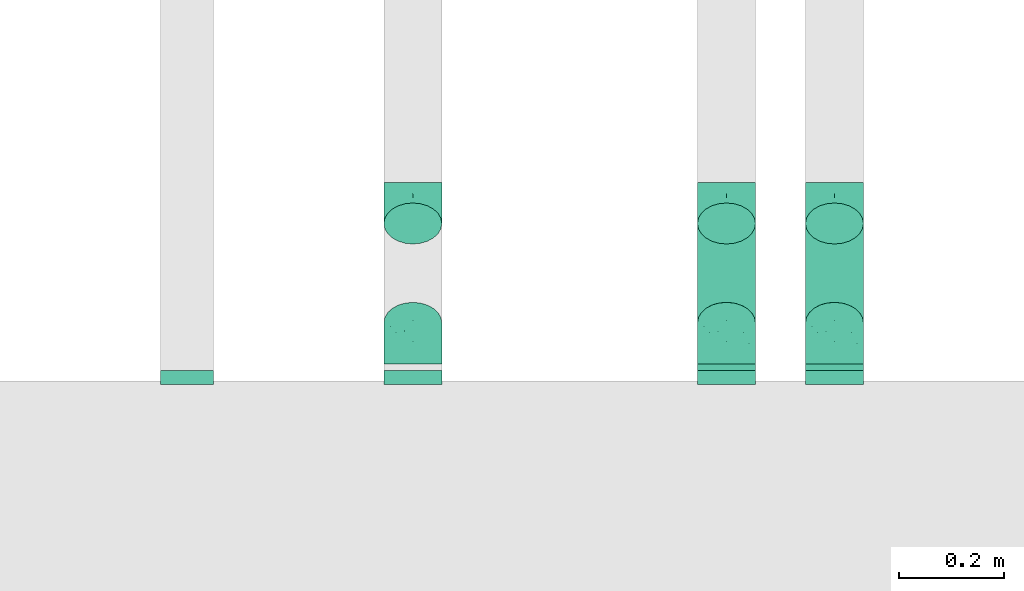
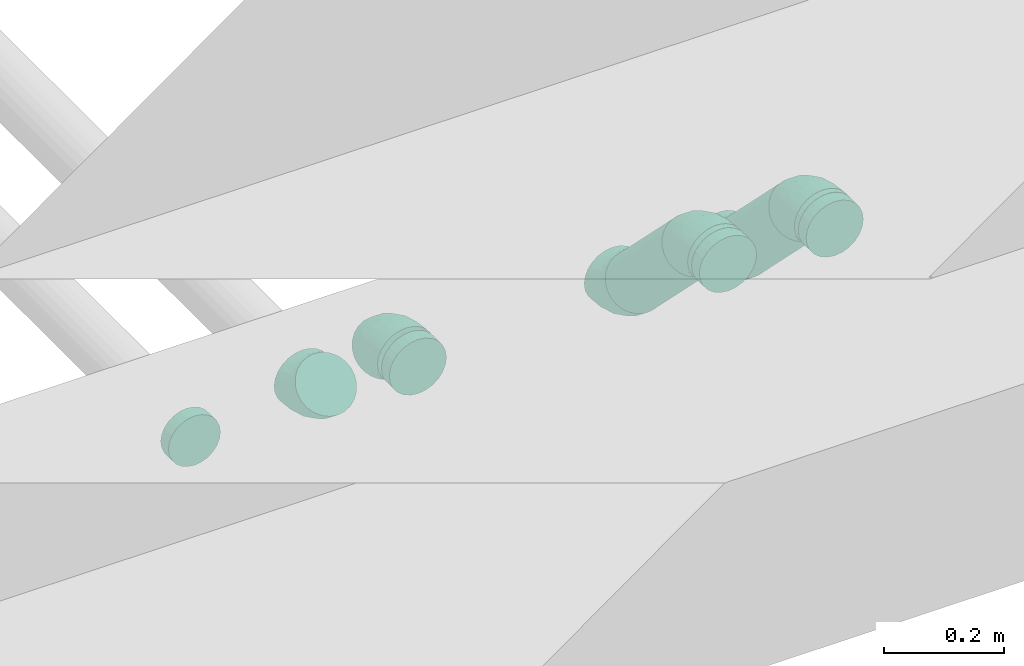
# One storey, part 33 of 91: 10 flow fittings, 4 flow segments.
"""IFC2X3 building model written with IfcOpenShell, lengths in millimetres."""

from ifc_helpers import new_model, entity, si_unit, converted_unit, derived_unit, direction, frame, origin_with_axes, origin_2d_with_axis, place, context, subcontext, project, spatial, hollow_circle, extrude, open_shell, surface_model, source, transform, mapped, material, layer, layer_set, layer_usage, type_object, element, save


model = new_model("IFC2X3")

# Units and contexts
model_context = context("Model", 3, precision=1e-05, world=origin_with_axes(), true_north=direction((0.0, 1.0)))
body_context = subcontext(model_context, "Body", "Model", "MODEL_VIEW")
ifc_project = project(units=[si_unit("AREAUNIT", "SQUARE_METRE"), si_unit("VOLUMEUNIT", "CUBIC_METRE", prefix="DECI"), si_unit("TIMEUNIT", "SECOND"), si_unit("THERMODYNAMICTEMPERATUREUNIT", "DEGREE_CELSIUS"), si_unit("PRESSUREUNIT", "PASCAL"), si_unit("MASSUNIT", "GRAM", prefix="KILO"), si_unit("LENGTHUNIT", "METRE", prefix="MILLI"), si_unit("POWERUNIT", "WATT"), si_unit("ELECTRICCURRENTUNIT", "AMPERE"), si_unit("ELECTRICVOLTAGEUNIT", "VOLT"), derived_unit("VOLUMETRICFLOWRATEUNIT", [(si_unit("VOLUMEUNIT", "CUBIC_METRE", prefix="DECI"), 1), (si_unit("TIMEUNIT", "SECOND"), -1)]), derived_unit("LINEARVELOCITYUNIT", [(si_unit("LENGTHUNIT", "METRE"), 1), (si_unit("TIMEUNIT", "SECOND"), -1)]), derived_unit("MASSDENSITYUNIT", [(si_unit("MASSUNIT", "GRAM", prefix="KILO"), 1), (si_unit("VOLUMEUNIT", "CUBIC_METRE"), -1)]), converted_unit("PLANEANGLEUNIT", "DEGREE", entity("IfcRatioMeasure", 0.01745), si_unit("PLANEANGLEUNIT", "RADIAN"), dimensions=[0, 0, 0, 0, 0, 0, 0])], contexts=[model_context])

# Site, building, storey
site_placement = place(None, origin_with_axes())
site = spatial("IfcSite", under=ifc_project, at=site_placement, CompositionType="ELEMENT")
building_placement = place(site_placement, origin_with_axes())
building = spatial("IfcBuilding", under=site, at=building_placement, Name="mc-building", CompositionType="ELEMENT")
storey_placement = place(building_placement, frame((0.0, 0.0, 8700.0), z_axis=(0.0, 0.0, 1.0), x_axis=(1.0, 0.0, 0.0)))
storey = spatial("IfcBuildingStorey", under=building, at=storey_placement, CompositionType="ELEMENT", Elevation=8700.0)

# Flow segments
ifc_material = material(Name="FZ1")
ifc_layer = layer(ifc_material, 0.0)
ifc_layer_set = layer_set([ifc_layer], Name="FZ1")
ifc_layer_usage = layer_usage(ifc_layer_set, "AXIS1", "POSITIVE", 0.0)
duct_segment_type = type_object("IfcDuctSegmentType", PredefinedType="RIGIDSEGMENT")
shared_shape_1 = source(origin_with_axes(), body_context, "Body", "SweptSolid", [
    extrude(hollow_circle(Radius=55.0, WallThickness=2.0, at=origin_2d_with_axis()), frame((0.0, 0.0, 0.0), z_axis=(1.0, 0.0, 0.0), x_axis=(0.0, 1.0, 0.0)), (0.0, 0.0, 1.0), 266.7),
])
for number, where, z_axis, x_axis in (
    (1, (15757.14677, 8401.1274, 635.78175), (0.0, 0.707107, 0.707107), (0.0, 0.707107, -0.707107)),
    (2, (15552.24709, 8401.1274, 635.78175), (0.0, 0.707107, 0.707107), (0.0, 0.707107, -0.707107)),
):
    element("IfcFlowSegment", number, at=place(storey_placement, frame(where, z_axis=z_axis, x_axis=x_axis)), inside=storey, type_object=duct_segment_type, material=ifc_layer_usage, context=body_context, shape_type="MappedRepresentation", body=[
        mapped(shared_shape_1, transform((0.0, 0.0, 0.0), scale=1.0)),
    ])

# Flow fittings
duct_fitting_type_1 = type_object("IfcDuctFittingType", Name="BU", PredefinedType="BEND")
shared_shape_2 = source(origin_with_axes(), body_context, "Body", "SurfaceModel", [
    surface_model("IfcShellBasedSurfaceModel", [(-45.56349, 0.0, -55.0), (-45.56349, -14.23505, -53.12592), (-45.56349, 14.23505, -53.12592), (-45.56349, 53.12592, 14.23505), (-45.56349, 27.5, -47.63139), (-45.56349, 38.89087, -38.89087), (-45.56349, 47.63139, -27.5), (-45.56349, -55.0, 0.0), (-45.56349, -53.12592, 14.23505), (-45.56349, -38.89087, -38.89087), (-45.56349, -27.5, -47.63139), (-45.56349, -53.12592, -14.23505), (-45.56349, -47.63139, -27.5), (-45.56349, 53.12592, -14.23505), (-45.56349, 47.63139, 27.5), (-45.56349, 38.89087, 38.89087), (-45.56349, -14.23505, 53.12592), (-45.56349, 27.5, 47.63139), (-45.56349, 14.23505, 53.12592), (-45.56349, -47.63139, 27.5), (-45.56349, -38.89087, 38.89087), (-45.56349, -27.5, 47.63139), (-45.56349, 0.0, 55.0), (-45.56349, 55.0, 0.0), (22.15256, 42.28395, -53.12592), (-6.67262, 71.10913, 0.0), (32.21826, 32.21826, -55.0), (12.77282, 51.66369, -47.63139), (-1.46223, 65.89874, -27.5), (4.71825, 59.71825, -38.89087), (59.71825, 4.71825, -38.89087), (69.78395, -5.34744, 14.23505), (51.66369, 12.77282, -47.63139), (42.28395, 22.15256, -53.12592), (65.89874, -1.46223, -27.5), (69.78395, -5.34744, -14.23505), (71.10913, -6.67262, 0.0), (-5.34744, 69.78395, -14.23505), (-5.34744, 69.78395, 14.23505), (-1.46223, 65.89874, 27.5), (4.71825, 59.71825, 38.89087), (32.21826, 32.21826, 55.0), (12.77282, 51.66369, 47.63139), (22.15256, 42.28395, 53.12592), (59.71825, 4.71825, 38.89087), (65.89874, -1.46223, 27.5), (42.28395, 22.15256, 53.12592), (51.66369, 12.77282, 47.63139), (-20.16649, 48.68621, 33.48188), (-26.97111, 35.77503, 43.63444), (-7.30443, 43.73336, 43.63444), (-17.0934, 3.74816, 55.0), (-18.00408, 15.44793, 53.78143), (-30.11707, 22.39897, 50.81337), (-7.49776, 55.63651, 33.48188), (-15.97018, 58.74288, 21.04759), (-31.18231, 52.58712, 21.04759), (-18.35174, 61.03934, 10.51509), (-28.67677, 56.60048, 10.47121), (-34.03924, 44.64267, 33.48188), (-11.52288, 27.81868, 50.81338), (1.19951, 23.16465, 53.81115), (-33.77926, 57.34403, 0.0), (5.4586, 37.12132, 50.81809), (-24.5159, 59.18663, 0.0), (-16.66281, 64.4339, 0.0), (9.43651, 14.73721, 55.0), (-6.22531, 44.36822, -43.63444), (5.4586, 37.12132, -50.81809), (-34.03924, 44.64267, -33.48188), (9.43651, 14.73721, -55.0), (-17.0934, 3.74816, -55.0), (1.19951, 23.16465, -53.81115), (-11.52288, 27.81868, -50.81338), (-30.11707, 22.39897, -50.81337), (-25.75914, 36.08917, -43.63444), (-30.24487, 52.83011, -21.04759), (-20.16649, 48.68621, -33.48188), (-7.49776, 55.63651, -33.48188), (-18.00408, 15.44793, -53.78143), (-28.68366, 56.62226, -10.35271), (-14.15883, 63.53074, -10.87592), (-15.13548, 59.23394, -21.04759), (3.19797, -7.72059, -52.16847), (3.1272, -18.04126, -47.9241), (13.63233, -32.91136, -32.06475), (45.23618, -22.99734, -20.4997), (16.67434, -40.25541, -15.9539), (-17.3935, -51.68264, -9.80849), (-2.85835, -49.37776, 0.0), (48.84421, -24.24609, -9.80849), (-16.38424, -42.76862, -30.85433), (-6.97383, -29.41689, -42.70541), (41.82739, -18.65658, -30.85433), (-15.72523, -48.24839, -20.4997), (29.28945, -13.63928, -42.80781), (26.81493, -3.56603, -49.15704), (36.93651, -32.89419, 0.0), (-15.72523, -48.24839, 20.4997), (-17.3935, -51.68264, 9.80849), (-16.38424, -42.76862, 30.85433), (16.67434, -40.25541, 15.9539), (3.19797, -7.72059, 52.16847), (10.54583, -14.96836, 47.9241), (13.63233, -32.91136, 32.06475), (45.23618, -22.99734, 20.4997), (41.82739, -18.65658, 30.85433), (-11.06635, -30.3552, 42.80781), (25.73213, -15.86964, 42.70541), (-16.43945, -21.48258, 49.15704), (48.84421, -24.24609, 9.80849)], [open_shell([[[0, 1, 2]], [[2, 3, 4]], [[5, 3, 6]], [[4, 3, 5]], [[2, 7, 8]], [[9, 7, 10]], [[1, 10, 7]], [[11, 7, 12]], [[9, 12, 7]], [[7, 2, 1]], [[13, 6, 3]], [[14, 3, 2]], [[15, 14, 2]], [[16, 17, 2]], [[2, 17, 15]], [[16, 18, 17]], [[19, 20, 2]], [[19, 2, 8]], [[20, 21, 2]], [[2, 21, 16]], [[16, 22, 18]], [[23, 13, 3]], [[24, 25, 26]], [[27, 25, 24]], [[28, 25, 29]], [[29, 25, 27]], [[30, 26, 31]], [[26, 30, 32]], [[32, 33, 26]], [[34, 31, 35]], [[31, 34, 30]], [[35, 31, 36]], [[37, 25, 28]], [[26, 38, 39]], [[26, 39, 40]], [[41, 40, 42]], [[26, 40, 41]], [[42, 43, 41]], [[26, 44, 45]], [[31, 26, 45]], [[46, 47, 26]], [[47, 44, 26]], [[46, 26, 41]], [[26, 25, 38]], [[48, 49, 50]], [[22, 51, 52]], [[17, 49, 15]], [[53, 17, 18]], [[49, 17, 53]], [[54, 50, 40]], [[48, 55, 56]], [[55, 57, 58]], [[59, 14, 15]], [[60, 53, 52]], [[50, 49, 60]], [[58, 3, 56]], [[52, 51, 61]], [[62, 23, 3]], [[63, 50, 60]], [[50, 42, 40]], [[3, 58, 62]], [[43, 61, 41]], [[62, 58, 64]], [[48, 59, 49]], [[14, 56, 3]], [[40, 39, 54]], [[57, 64, 58]], [[39, 38, 55]], [[63, 60, 61]], [[54, 55, 48]], [[65, 57, 38]], [[56, 14, 59]], [[38, 25, 65]], [[60, 52, 61]], [[49, 59, 15]], [[55, 58, 56]], [[56, 59, 48]], [[55, 54, 39]], [[50, 54, 48]], [[18, 22, 52]], [[49, 53, 60]], [[18, 52, 53]], [[61, 51, 66]], [[41, 61, 66]], [[63, 61, 43]], [[43, 42, 63]], [[50, 63, 42]], [[38, 57, 55]], [[64, 57, 65]], [[67, 27, 68]], [[69, 5, 6]], [[70, 71, 72]], [[73, 74, 75]], [[76, 77, 69]], [[29, 78, 28]], [[2, 79, 0]], [[13, 23, 62]], [[2, 74, 79]], [[5, 75, 4]], [[77, 78, 67]], [[13, 62, 80]], [[64, 80, 62]], [[81, 80, 64]], [[67, 73, 75]], [[82, 77, 76]], [[81, 64, 65]], [[76, 69, 6]], [[82, 76, 80]], [[24, 72, 68]], [[74, 2, 4]], [[27, 67, 29]], [[26, 70, 72]], [[69, 75, 5]], [[82, 28, 78]], [[72, 71, 79]], [[6, 13, 76]], [[77, 67, 75]], [[13, 80, 76]], [[82, 37, 28]], [[81, 25, 37]], [[82, 81, 37]], [[75, 69, 77]], [[67, 78, 29]], [[82, 78, 77]], [[75, 74, 4]], [[79, 74, 73]], [[79, 73, 72]], [[79, 71, 0]], [[68, 72, 73]], [[26, 72, 24]], [[67, 68, 73]], [[27, 24, 68]], [[80, 81, 82]], [[25, 81, 65]], [[1, 83, 84]], [[85, 86, 87]], [[0, 71, 1]], [[88, 87, 89]], [[90, 86, 35]], [[91, 92, 85]], [[11, 88, 7]], [[30, 34, 93]], [[11, 12, 94]], [[92, 91, 9]], [[85, 94, 91]], [[94, 85, 87]], [[95, 93, 85]], [[85, 92, 95]], [[83, 71, 70]], [[12, 9, 91]], [[70, 26, 33]], [[96, 84, 83]], [[1, 71, 83]], [[95, 96, 32]], [[95, 30, 93]], [[95, 32, 30]], [[97, 89, 87]], [[34, 86, 93]], [[36, 97, 90]], [[94, 88, 11]], [[34, 35, 86]], [[90, 87, 86]], [[93, 86, 85]], [[32, 96, 33]], [[84, 10, 1]], [[33, 83, 70]], [[94, 12, 91]], [[10, 92, 9]], [[87, 88, 94]], [[7, 88, 89]], [[36, 90, 35]], [[87, 90, 97]], [[84, 95, 92]], [[33, 96, 83]], [[95, 84, 96]], [[10, 84, 92]], [[8, 98, 19]], [[7, 89, 99]], [[19, 98, 100]], [[101, 98, 99]], [[46, 102, 103]], [[104, 105, 106]], [[100, 98, 104]], [[107, 104, 108]], [[16, 51, 22]], [[51, 16, 102]], [[107, 20, 100]], [[107, 109, 21]], [[21, 20, 107]], [[103, 47, 46]], [[101, 89, 97]], [[105, 110, 31]], [[44, 47, 108]], [[105, 104, 101]], [[107, 100, 104]], [[31, 110, 36]], [[109, 16, 21]], [[108, 106, 44]], [[105, 45, 106]], [[41, 66, 46]], [[102, 66, 51]], [[46, 66, 102]], [[104, 98, 101]], [[99, 98, 8]], [[106, 108, 104]], [[110, 101, 97]], [[45, 44, 106]], [[105, 31, 45]], [[20, 19, 100]], [[109, 103, 102]], [[101, 110, 105]], [[36, 110, 97]], [[7, 99, 8]], [[101, 99, 89]], [[103, 107, 108]], [[16, 109, 102]], [[107, 103, 109]], [[47, 103, 108]]])]),
])
for number, where, z_axis, x_axis, name in (
    (3, (14957.14677, 8368.90914, 668.0), (1.0, 0.0, 0.0), (0.0, -0.707107, 0.707107), "BU"),
    (4, (14957.14677, 8621.90914, 415.0), (-1.0, 0.0, 0.0), (0.0, -1.0, 0.0), "BU"),
    (5, (15757.14677, 8368.90914, 668.0), (1.0, 0.0, 0.0), (0.0, -0.707107, 0.707107), "BU"),
    (6, (15757.14677, 8621.90914, 415.0), (-1.0, 0.0, 0.0), (0.0, -1.0, 0.0), "BU"),
    (7, (15552.24709, 8368.90914, 668.0), (1.0, 0.0, 0.0), (0.0, -0.707107, 0.707107), "BU"),
    (8, (15552.24709, 8621.90914, 415.0), (-1.0, 0.0, 0.0), (0.0, -1.0, 0.0), "BU"),
):
    element("IfcFlowFitting", number, at=place(storey_placement, frame(where, z_axis=z_axis, x_axis=x_axis)), inside=storey, type_object=duct_fitting_type_1, Name=name, context=body_context, shape_type="MappedRepresentation", body=[
        mapped(shared_shape_2, transform((0.0, 0.0, 0.0), scale=1.0)),
    ])
duct_fitting_type_2 = type_object("IfcDuctFittingType", Name="CC", PredefinedType="CONNECTOR")
shared_shape_3 = source(origin_with_axes(), body_context, "Body", "SurfaceModel", [
    surface_model("IfcShellBasedSurfaceModel", [(-6.096, -55.0, 0.0), (-6.096, 0.0, -55.0), (-6.096, -14.23505, -53.12592), (-6.096, -27.5, -47.63139), (-6.096, -38.89087, -38.89087), (-6.096, -47.63139, -27.5), (-6.096, 38.89087, -38.89087), (-6.096, 53.12592, 14.23505), (-6.096, 27.5, -47.63139), (-6.096, 14.23505, -53.12592), (-6.096, 47.63139, -27.5), (-6.096, 53.12592, -14.23505), (-6.096, 55.0, 0.0), (-6.096, -53.12592, -14.23505), (-6.096, -53.12592, 14.23505), (-6.096, -47.63139, 27.5), (-6.096, -38.89087, 38.89087), (-6.096, 0.0, 55.0), (-6.096, -27.5, 47.63139), (-6.096, -14.23505, 53.12592), (-6.096, 38.89087, 38.89087), (-6.096, 47.63139, 27.5), (-6.096, 14.23505, 53.12592), (-6.096, 27.5, 47.63139), (0.0, -14.23505, 53.12592), (0.0, 0.0, 55.0), (0.0, -27.5, 47.63139), (0.0, -38.89087, 38.89087), (0.0, -53.12592, 14.23505), (0.0, -47.63139, 27.5), (0.0, -55.0, 0.0), (0.0, -53.12592, -14.23505), (0.0, -47.63139, -27.5), (0.0, -38.89087, -38.89087), (0.0, -14.23505, -53.12592), (0.0, -27.5, -47.63139), (0.0, 0.0, -55.0), (0.0, 14.23505, -53.12592), (0.0, 27.5, -47.63139), (0.0, 38.89087, -38.89087), (0.0, 53.12592, -14.23505), (0.0, 47.63139, -27.5), (0.0, 55.0, 0.0), (0.0, 53.12592, 14.23505), (0.0, 47.63139, 27.5), (0.0, 38.89087, 38.89087), (0.0, 14.23505, 53.12592), (0.0, 27.5, 47.63139), (20.0, 0.0, -55.0), (20.0, 14.23505, -53.12592), (20.0, -14.23505, -53.12592), (20.0, -53.12592, 14.23505), (20.0, -27.5, -47.63139), (20.0, -47.63139, -27.5), (20.0, -38.89087, -38.89087), (20.0, 55.0, 0.0), (20.0, 53.12592, 14.23505), (20.0, 38.89087, -38.89087), (20.0, 27.5, -47.63139), (20.0, 53.12592, -14.23505), (20.0, 47.63139, -27.5), (20.0, -53.12592, -14.23505), (20.0, -47.63139, 27.5), (20.0, -38.89087, 38.89087), (20.0, 14.23505, 53.12592), (20.0, -27.5, 47.63139), (20.0, -14.23505, 53.12592), (20.0, 47.63139, 27.5), (20.0, 38.89087, 38.89087), (20.0, 27.5, 47.63139), (20.0, 0.0, 55.0), (20.0, -55.0, 0.0)], [open_shell([[[0, 1, 2]], [[3, 0, 2]], [[0, 4, 5]], [[4, 0, 3]], [[6, 1, 7]], [[1, 6, 8]], [[8, 9, 1]], [[6, 7, 10]], [[10, 7, 11]], [[12, 11, 7]], [[13, 0, 5]], [[14, 15, 1]], [[1, 15, 16]], [[17, 16, 18]], [[17, 1, 16]], [[19, 17, 18]], [[20, 21, 1]], [[7, 1, 21]], [[22, 23, 1]], [[23, 20, 1]], [[22, 1, 17]], [[0, 14, 1]], [[24, 25, 17]], [[26, 24, 19]], [[19, 24, 17]], [[16, 27, 18]], [[26, 19, 18]], [[26, 18, 27]], [[28, 29, 15]], [[30, 28, 14]], [[15, 29, 16]], [[28, 15, 14]], [[30, 14, 0]], [[27, 16, 29]], [[31, 30, 0]], [[32, 31, 13]], [[13, 31, 0]], [[4, 33, 5]], [[32, 13, 5]], [[32, 5, 33]], [[34, 35, 3]], [[36, 34, 2]], [[3, 35, 4]], [[34, 3, 2]], [[36, 2, 1]], [[33, 4, 35]], [[37, 36, 1]], [[38, 37, 9]], [[9, 37, 1]], [[6, 39, 8]], [[38, 9, 8]], [[38, 8, 39]], [[40, 41, 10]], [[42, 40, 11]], [[10, 41, 6]], [[40, 10, 11]], [[42, 11, 12]], [[39, 6, 41]], [[43, 42, 12]], [[44, 43, 7]], [[7, 43, 12]], [[20, 45, 21]], [[44, 7, 21]], [[44, 21, 45]], [[46, 47, 23]], [[25, 46, 22]], [[23, 47, 20]], [[46, 23, 22]], [[25, 22, 17]], [[45, 20, 47]], [[48, 49, 50]], [[50, 51, 52]], [[53, 54, 51]], [[52, 51, 54]], [[50, 55, 56]], [[57, 55, 58]], [[49, 58, 55]], [[59, 55, 60]], [[57, 60, 55]], [[55, 50, 49]], [[53, 51, 61]], [[50, 62, 51]], [[63, 62, 50]], [[64, 65, 50]], [[65, 63, 50]], [[64, 66, 65]], [[50, 67, 68]], [[67, 50, 56]], [[68, 69, 50]], [[50, 69, 64]], [[64, 70, 66]], [[71, 61, 51]], [[66, 70, 25]], [[65, 66, 24]], [[24, 66, 25]], [[27, 63, 26]], [[65, 24, 26]], [[65, 26, 63]], [[51, 62, 29]], [[71, 51, 28]], [[29, 62, 27]], [[51, 29, 28]], [[71, 28, 30]], [[63, 27, 62]], [[61, 71, 30]], [[53, 61, 31]], [[31, 61, 30]], [[33, 54, 32]], [[53, 31, 32]], [[53, 32, 54]], [[50, 52, 35]], [[48, 50, 34]], [[35, 52, 33]], [[50, 35, 34]], [[48, 34, 36]], [[54, 33, 52]], [[49, 48, 36]], [[58, 49, 37]], [[37, 49, 36]], [[39, 57, 38]], [[58, 37, 38]], [[58, 38, 57]], [[59, 60, 41]], [[55, 59, 40]], [[41, 60, 39]], [[59, 41, 40]], [[55, 40, 42]], [[57, 39, 60]], [[56, 55, 42]], [[67, 56, 43]], [[43, 56, 42]], [[45, 68, 44]], [[67, 43, 44]], [[67, 44, 68]], [[64, 69, 47]], [[70, 64, 46]], [[47, 69, 45]], [[64, 47, 46]], [[70, 46, 25]], [[68, 45, 69]], [[50, 63, 62]], [[50, 64, 65]], [[50, 56, 67]], [[50, 68, 69]], [[64, 50, 69]]])]),
])
for number, where, z_axis, x_axis, name in (
    (9, (15757.14677, 8290.34565, 668.0), (0.0, 0.0, -1.0), (0.0, 1.0, 0.0), "CC"),
    (10, (15552.24709, 8290.34565, 668.0), (0.0, 0.0, -1.0), (0.0, 1.0, 0.0), "CC"),
    (11, (14957.14677, 8290.34565, 668.0), (0.0, 0.0, -1.0), (0.0, 1.0, 0.0), "CC"),
):
    element("IfcFlowFitting", number, at=place(storey_placement, frame(where, z_axis=z_axis, x_axis=x_axis)), inside=storey, type_object=duct_fitting_type_2, Name=name, context=body_context, shape_type="MappedRepresentation", body=[
        mapped(shared_shape_3, transform((0.0, 0.0, 0.0), scale=1.0)),
    ])
shared_shape_4 = source(origin_with_axes(), body_context, "Body", "SurfaceModel", [
    surface_model("IfcShellBasedSurfaceModel", [(-6.096, -12.94095, -48.29629), (-6.096, -50.0, 0.0), (-6.096, 0.0, -50.0), (-6.096, -25.0, -43.30127), (-6.096, -35.35534, -35.35534), (-6.096, -43.30127, -25.0), (-6.096, 35.35534, -35.35534), (-6.096, 48.29629, 12.94095), (-6.096, 25.0, -43.30127), (-6.096, 12.94095, -48.29629), (-6.096, 43.30127, -25.0), (-6.096, 48.29629, -12.94095), (-6.096, 50.0, 0.0), (-6.096, -48.29629, -12.94095), (-6.096, -48.29629, 12.94095), (-6.096, -43.30127, 25.0), (-6.096, -35.35534, 35.35534), (-6.096, -25.0, 43.30127), (-6.096, 0.0, 50.0), (-6.096, -12.94095, 48.29629), (-6.096, 43.30127, 25.0), (-6.096, 35.35534, 35.35534), (-6.096, 25.0, 43.30127), (-6.096, 12.94095, 48.29629), (0.0, -12.94095, 48.29629), (0.0, 0.0, 50.0), (0.0, -25.0, 43.30127), (0.0, -35.35534, 35.35534), (0.0, -48.29629, 12.94095), (0.0, -43.30127, 25.0), (0.0, -50.0, 0.0), (0.0, -48.29629, -12.94095), (0.0, -43.30127, -25.0), (0.0, -35.35534, -35.35534), (0.0, -12.94095, -48.29629), (0.0, -25.0, -43.30127), (0.0, 0.0, -50.0), (0.0, 12.94095, -48.29629), (0.0, 25.0, -43.30127), (0.0, 35.35534, -35.35534), (0.0, 48.29629, -12.94095), (0.0, 43.30127, -25.0), (0.0, 50.0, 0.0), (0.0, 48.29629, 12.94095), (0.0, 43.30127, 25.0), (0.0, 35.35534, 35.35534), (0.0, 12.94095, 48.29629), (0.0, 25.0, 43.30127), (20.0, 0.0, -50.0), (20.0, 12.94095, -48.29629), (20.0, -12.94095, -48.29629), (20.0, -48.29629, 12.94095), (20.0, -25.0, -43.30127), (20.0, -43.30127, -25.0), (20.0, -35.35534, -35.35534), (20.0, 50.0, 0.0), (20.0, 48.29629, 12.94095), (20.0, 35.35534, -35.35534), (20.0, 25.0, -43.30127), (20.0, 48.29629, -12.94095), (20.0, 43.30127, -25.0), (20.0, -48.29629, -12.94095), (20.0, -43.30127, 25.0), (20.0, -35.35534, 35.35534), (20.0, -25.0, 43.30127), (20.0, 12.94095, 48.29629), (20.0, -12.94095, 48.29629), (20.0, 43.30127, 25.0), (20.0, 35.35534, 35.35534), (20.0, 25.0, 43.30127), (20.0, 0.0, 50.0), (20.0, -50.0, 0.0)], [open_shell([[[0, 1, 2]], [[3, 1, 0]], [[1, 4, 5]], [[4, 1, 3]], [[6, 2, 7]], [[2, 6, 8]], [[8, 9, 2]], [[10, 7, 11]], [[7, 10, 6]], [[11, 7, 12]], [[5, 13, 1]], [[2, 14, 15]], [[2, 15, 16]], [[17, 18, 16]], [[18, 2, 16]], [[19, 18, 17]], [[2, 20, 7]], [[21, 20, 2]], [[22, 21, 2]], [[23, 22, 2]], [[23, 2, 18]], [[2, 1, 14]], [[24, 25, 18]], [[26, 24, 19]], [[19, 24, 18]], [[16, 27, 17]], [[26, 19, 17]], [[26, 17, 27]], [[28, 29, 15]], [[30, 28, 14]], [[15, 29, 16]], [[28, 15, 14]], [[30, 14, 1]], [[27, 16, 29]], [[31, 30, 1]], [[32, 31, 13]], [[13, 31, 1]], [[4, 33, 5]], [[32, 13, 5]], [[32, 5, 33]], [[34, 35, 3]], [[36, 34, 0]], [[3, 35, 4]], [[34, 3, 0]], [[36, 0, 2]], [[33, 4, 35]], [[37, 36, 2]], [[38, 37, 9]], [[9, 37, 2]], [[6, 39, 8]], [[38, 9, 8]], [[38, 8, 39]], [[40, 41, 10]], [[42, 40, 11]], [[10, 41, 6]], [[40, 10, 11]], [[42, 11, 12]], [[39, 6, 41]], [[43, 42, 12]], [[44, 43, 7]], [[7, 43, 12]], [[21, 45, 20]], [[44, 7, 20]], [[44, 20, 45]], [[46, 47, 22]], [[25, 46, 23]], [[22, 47, 21]], [[46, 22, 23]], [[25, 23, 18]], [[45, 21, 47]], [[48, 49, 50]], [[50, 51, 52]], [[53, 54, 51]], [[52, 51, 54]], [[50, 55, 56]], [[57, 55, 58]], [[49, 58, 55]], [[59, 55, 60]], [[57, 60, 55]], [[55, 50, 49]], [[53, 51, 61]], [[62, 51, 50]], [[63, 62, 50]], [[64, 50, 65]], [[64, 63, 50]], [[64, 65, 66]], [[56, 67, 50]], [[50, 67, 68]], [[50, 68, 69]], [[65, 50, 69]], [[65, 70, 66]], [[71, 61, 51]], [[66, 70, 25]], [[64, 66, 24]], [[24, 66, 25]], [[27, 63, 26]], [[64, 24, 26]], [[64, 26, 63]], [[51, 62, 29]], [[71, 51, 28]], [[29, 62, 27]], [[51, 29, 28]], [[71, 28, 30]], [[63, 27, 62]], [[61, 71, 30]], [[53, 61, 31]], [[31, 61, 30]], [[33, 54, 32]], [[53, 31, 32]], [[53, 32, 54]], [[50, 52, 35]], [[48, 50, 34]], [[35, 52, 33]], [[50, 35, 34]], [[48, 34, 36]], [[54, 33, 52]], [[49, 48, 36]], [[58, 49, 37]], [[37, 49, 36]], [[39, 57, 38]], [[58, 37, 38]], [[58, 38, 57]], [[59, 60, 41]], [[55, 59, 40]], [[41, 60, 39]], [[59, 41, 40]], [[55, 40, 42]], [[57, 39, 60]], [[56, 55, 42]], [[67, 56, 43]], [[43, 56, 42]], [[45, 68, 44]], [[67, 43, 44]], [[67, 44, 68]], [[65, 69, 47]], [[70, 65, 46]], [[47, 69, 45]], [[65, 47, 46]], [[70, 46, 25]], [[68, 45, 69]], [[50, 56, 67]], [[68, 69, 50]], [[18, 16, 17]], [[17, 19, 18]]])]),
])
flow_fitting_placement = place(storey_placement, frame((14528.37491, 8290.34565, 668.0), z_axis=(0.0, 0.0, -1.0), x_axis=(0.0, 1.0, 0.0)))
element("IfcFlowFitting", 12, at=flow_fitting_placement, inside=storey, type_object=duct_fitting_type_2, Name="CC", context=body_context, shape_type="MappedRepresentation", body=[
    mapped(shared_shape_4, transform((0.0, 0.0, 0.0), scale=1.0)),
])

# Flow segments
shared_shape_5 = source(origin_with_axes(), body_context, "Body", "SweptSolid", [
    extrude(hollow_circle(Radius=55.0, WallThickness=2.0, at=origin_2d_with_axis()), frame((0.0, 0.0, 0.0), z_axis=(1.0, 0.0, 0.0), x_axis=(0.0, 1.0, 0.0)), (0.0, 0.0, 1.0), 13.0),
])
for number, where, z_axis, x_axis in (
    (13, (15757.14677, 8310.34565, 668.0), (0.0, 0.0, 1.0), (0.0, 1.0, 0.0)),
    (14, (15552.24709, 8310.34565, 668.0), (0.0, 0.0, 1.0), (0.0, 1.0, 0.0)),
):
    element("IfcFlowSegment", number, at=place(storey_placement, frame(where, z_axis=z_axis, x_axis=x_axis)), inside=storey, type_object=duct_segment_type, material=ifc_layer_usage, context=body_context, shape_type="MappedRepresentation", body=[
        mapped(shared_shape_5, transform((0.0, 0.0, 0.0), scale=1.0, scale2=1.0, scale3=1.0, uniform=False)),
    ])

save(model, "model.ifc")
